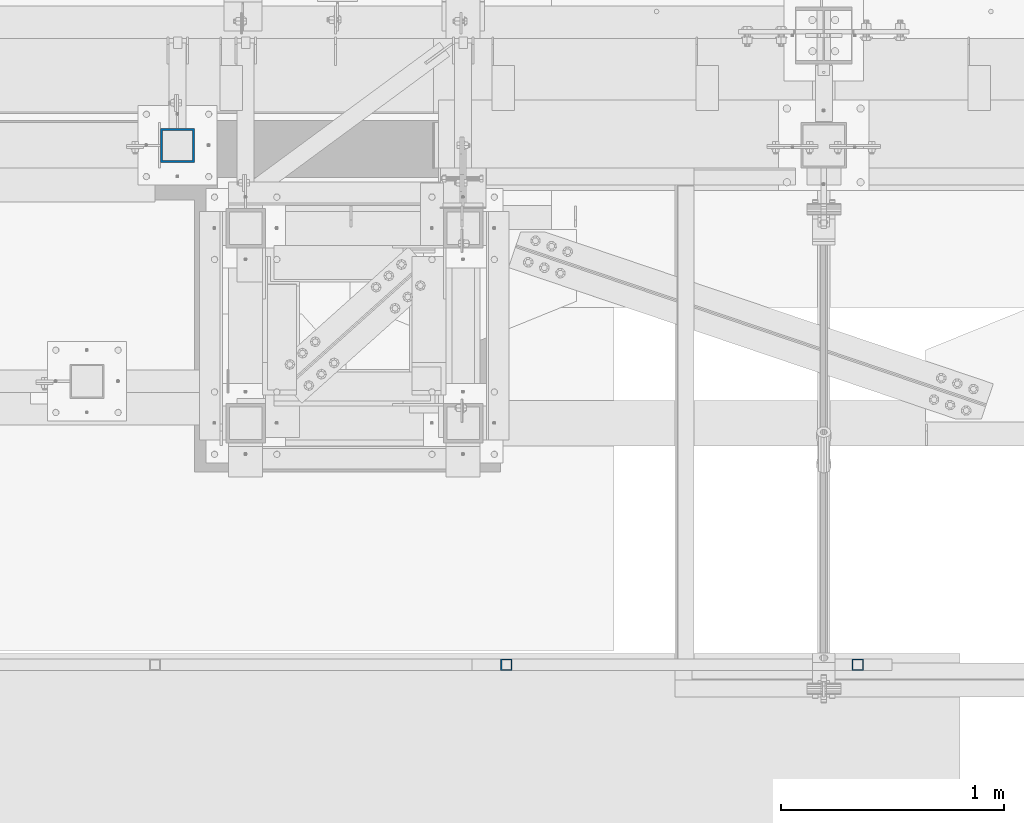
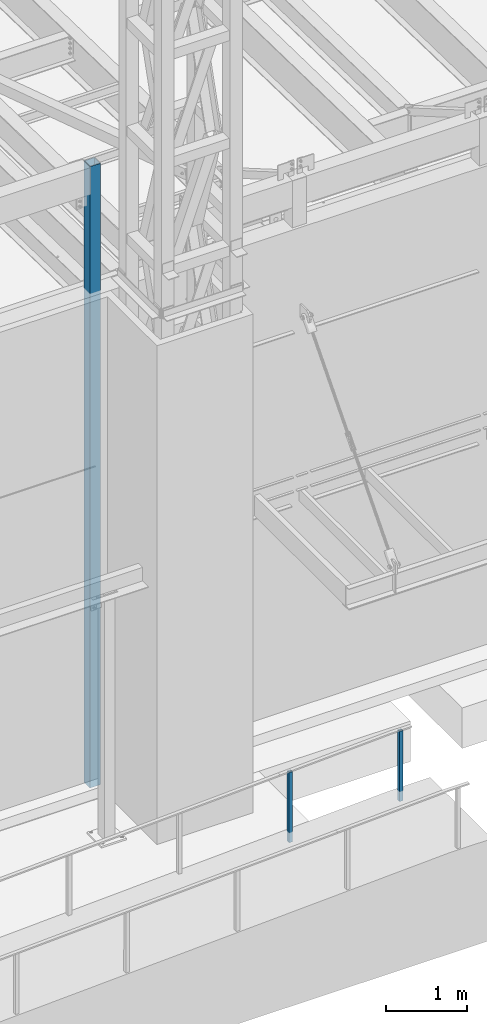
# One storey, part 890 of 1763: 3 columns, 2 elements without a shape of their own.
"""IFC2X3 building model written with IfcOpenShell, lengths in millimetres."""

from ifc_helpers import new_model, si_unit, frame, origin_with_axes, place, context, subcontext, project, spatial, faceted_brep, material, type_object, element, aggregate, save


model = new_model("IFC2X3")

# Units and contexts
model_context = context("Model", 3, precision=1e-05, world=origin_with_axes())
body_context = subcontext(model_context, "Body", "Model", "MODEL_VIEW")
ifc_project = project(units=[si_unit("LENGTHUNIT", "METRE", prefix="MILLI"), si_unit("AREAUNIT", "SQUARE_METRE"), si_unit("VOLUMEUNIT", "CUBIC_METRE"), si_unit("MASSUNIT", "GRAM", prefix="KILO"), si_unit("TIMEUNIT", "SECOND"), si_unit("PLANEANGLEUNIT", "RADIAN"), si_unit("SOLIDANGLEUNIT", "STERADIAN"), si_unit("THERMODYNAMICTEMPERATUREUNIT", "DEGREE_CELSIUS"), si_unit("LUMINOUSINTENSITYUNIT", "LUMEN")], contexts=[model_context])

# Site, building, storey
site_placement = place(None, origin_with_axes())
site = spatial("IfcSite", under=ifc_project, at=site_placement, CompositionType="ELEMENT")
building_placement = place(site_placement, origin_with_axes())
building = spatial("IfcBuilding", under=site, at=building_placement, Name="Undefined", CompositionType="ELEMENT")
storey_placement = place(building_placement, origin_with_axes())
storey = spatial("IfcBuildingStorey", under=building, at=storey_placement, Name="Undefined", CompositionType="ELEMENT", Elevation=0.0)

# Assembly, columns
assembly_1_placement = place(storey_placement, origin_with_axes())
assembly_1 = element("IfcElementAssembly", 1, at=assembly_1_placement, inside=storey, Name="HANDRAIL", AssemblyPlace="NOTDEFINED", PredefinedType="RIGID_FRAME")
ifc_material = material()
column_type_1 = type_object("IfcColumnType", Name="2X2X3/16 SQUARE TUBE SS", PredefinedType="NOTDEFINED")
column_1_placement = place(assembly_1_placement, frame((-63016.9000936682, -16535.4002326199, 5113.69667938172), z_axis=(-0.999999999891248, 0.0, 1.47479999968709e-05), x_axis=(1.47479999970212e-05, 0.0, 0.999999999891248)))
column_1 = element("IfcColumn", 2, at=column_1_placement, type_object=column_type_1, material=ifc_material, Name="POST TUBE", ObjectType="2X2X3/16 SQUARE TUBE SS", context=body_context, shape_type="Brep", body=[
    faceted_brep([(0.0, 20.6375000000007, -20.6374999999971), (0.0, -20.6375000000007, -20.6374999999971), (1058.23349084755, -20.6375000000007, -20.6375000024054), (1058.23349084755, 20.6375000000007, -20.6375000024054), (0.0, -20.6375000000007, 20.6374999999971), (1056.26220687483, -20.6375000000007, 20.6374999975815), (0.0, 20.6375000000007, 20.6374999999971), (1056.26220687483, 20.6375000000007, 20.6374999975815), (-1.45519152283669e-11, 25.4000000000015, -25.3999999999869), (1.45519152283669e-11, 25.4000000000015, 25.3999999999796), (1056.03475103182, 25.4000000000015, 25.3999999975786), (1058.46094669056, 25.4000000000015, -25.4000000024098), (0.0, -25.4000000000015, 25.3999999999942), (1056.03475103182, -25.4000000000015, 25.3999999975786), (-1.45519152283669e-11, -25.4000000000015, -25.3999999999869), (1058.46094669056, -25.4000000000015, -25.4000000024098)], [[[0, 1, 2, 3]], [[1, 4, 5, 2]], [[4, 6, 7, 5]], [[6, 0, 3, 7]], [[8, 9, 10, 11]], [[9, 12, 13, 10]], [[12, 14, 15, 13]], [[14, 8, 11, 15]], [[13, 15, 11, 10], [5, 7, 3, 2]], [[14, 12, 9, 8], [6, 4, 1, 0]]]),
])
column_2_placement = place(assembly_1_placement, frame((-61442.0231239422, -16535.4002326199, 5181.60498829066), z_axis=(-0.999999999891248, 0.0, 1.47479999968709e-05), x_axis=(1.47479999970212e-05, 0.0, 0.999999999891248)))
column_2 = element("IfcColumn", 3, at=column_2_placement, type_object=column_type_1, material=ifc_material, Name="POST TUBE", ObjectType="2X2X3/16 SQUARE TUBE SS", context=body_context, shape_type="Brep", body=[
    faceted_brep([(0.0, 20.6375000000007, -20.6374999999971), (0.0, -20.6375000000007, -20.6374999999971), (1057.27454565037, -20.6375000000007, -20.6375000024054), (1057.27454565037, 20.6375000000007, -20.6375000024054), (0.0, -20.6375000000007, 20.6374999999971), (1057.27361877886, -20.6375000000007, 20.6374999975815), (0.0, 20.6375000000007, 20.6374999999971), (1057.27361877886, 20.6375000000007, 20.6374999975815), (-1.45519152283669e-11, 25.4000000000015, -25.3999999999869), (1.45519152283669e-11, 25.4000000000015, 25.3999999999796), (1057.27351183214, 25.4000000000015, 25.3999999975786), (1057.27465259708, 25.4000000000015, -25.4000000024025), (0.0, -25.4000000000015, 25.3999999999942), (1057.27351183214, -25.4000000000015, 25.3999999975786), (-1.45519152283669e-11, -25.4000000000015, -25.3999999999869), (1057.27465259708, -25.4000000000015, -25.4000000024025)], [[[0, 1, 2, 3]], [[1, 4, 5, 2]], [[4, 6, 7, 5]], [[6, 0, 3, 7]], [[8, 9, 10, 11]], [[9, 12, 13, 10]], [[12, 14, 15, 13]], [[14, 8, 11, 15]], [[13, 15, 11, 10], [5, 7, 3, 2]], [[14, 12, 9, 8], [6, 4, 1, 0]]]),
])
aggregate(assembly_1, [column_1, column_2])

# Assembly, column
assembly_2_placement = place(storey_placement, origin_with_axes())
assembly_2 = element("IfcElementAssembly", 4, at=assembly_2_placement, inside=storey, Name="COLUMN", AssemblyPlace="NOTDEFINED", PredefinedType="RIGID_FRAME")
column_type_2 = type_object("IfcColumnType", Name="HSS6X6X3/8", PredefinedType="NOTDEFINED")
column_3_placement = place(assembly_2_placement, frame((-64490.482374092, -14208.1264769908, 5029.2), z_axis=(0.0, 1.0, 0.0), x_axis=(0.0, 0.0, 1.0)))
column_3 = element("IfcColumn", 5, at=column_3_placement, type_object=column_type_2, material=ifc_material, Name="COLUMN", ObjectType="HSS6X6X3/8", context=body_context, shape_type="Brep", body=[
    faceted_brep([(63.5000000000027, 66.6750000000029, -66.6749999999993), (63.5000000000027, -66.6750000000029, -66.6749999999993), (9429.75000000001, -66.6750000000029, -66.6749999999993), (9429.75000000001, 66.6750000000029, -66.6749999999993), (63.5000000000027, -66.6750000000029, 66.6749999999993), (9429.75000000001, -66.6750000000029, 66.6749999999993), (63.5000000000027, 66.6750000000029, 66.6749999999993), (9429.75000000001, 66.6750000000029, 66.6749999999993), (63.4999999999973, 76.1999999999971, -76.2000000000007), (63.4999999999973, 76.1999999999971, 76.2000000000007), (9429.75000000001, 76.1999999999971, 76.2000000000007), (9429.75000000001, 76.1999999999971, -76.2000000000007), (63.4999999999973, -76.1999999999971, 76.2000000000007), (9429.75000000001, -76.1999999999971, 76.2000000000007), (63.4999999999973, -76.1999999999971, -76.2000000000007), (9429.75000000001, -76.1999999999971, -76.2000000000007)], [[[0, 1, 2, 3]], [[1, 4, 5, 2]], [[4, 6, 7, 5]], [[6, 0, 3, 7]], [[8, 9, 10, 11]], [[9, 12, 13, 10]], [[12, 14, 15, 13]], [[14, 8, 11, 15]], [[13, 15, 11, 10], [5, 7, 3, 2]], [[14, 12, 9, 8], [6, 4, 1, 0]]]),
])
aggregate(assembly_2, [column_3])

save(model, "model.ifc")
